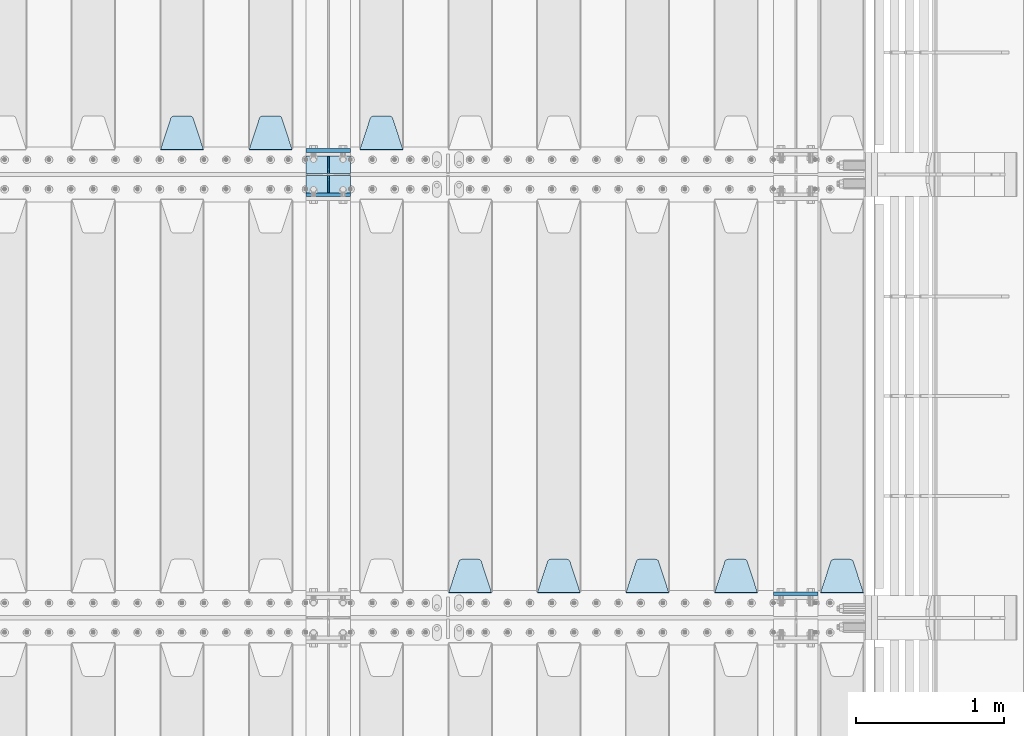
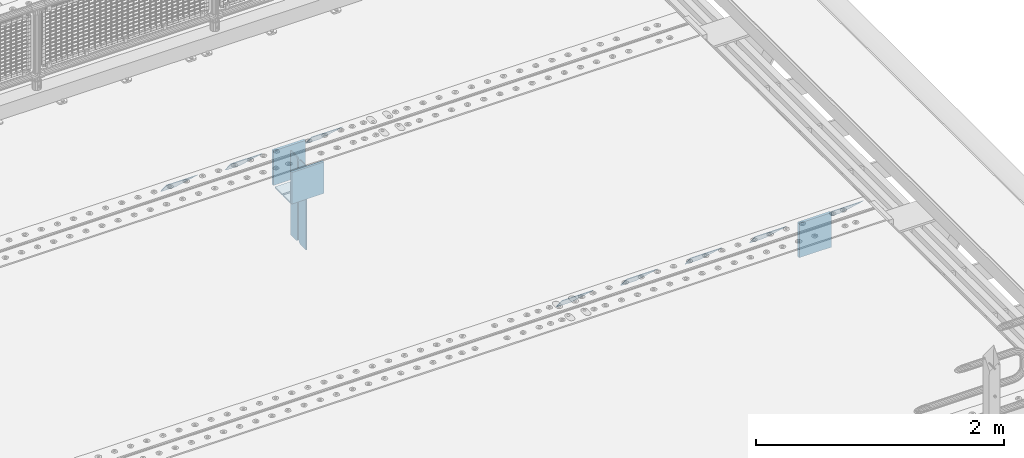
# One storey, part 189 of 219: 17 plates.
"""IFC2X3 building model written with IfcOpenShell, lengths in millimetres."""

from ifc_helpers import new_model, si_unit, frame, origin_with_axes, place, context, subcontext, project, spatial, faceted_brep, material, type_object, element, save


model = new_model("IFC2X3")

# Units and contexts
model_context = context("Model", 3, precision=1e-05, world=origin_with_axes())
body_context = subcontext(model_context, "Body", "Model", "MODEL_VIEW")
ifc_project = project(units=[si_unit("LENGTHUNIT", "METRE", prefix="MILLI"), si_unit("AREAUNIT", "SQUARE_METRE"), si_unit("VOLUMEUNIT", "CUBIC_METRE"), si_unit("MASSUNIT", "GRAM", prefix="KILO"), si_unit("TIMEUNIT", "SECOND"), si_unit("PLANEANGLEUNIT", "RADIAN"), si_unit("SOLIDANGLEUNIT", "STERADIAN"), si_unit("THERMODYNAMICTEMPERATUREUNIT", "DEGREE_CELSIUS"), si_unit("LUMINOUSINTENSITYUNIT", "LUMEN")], contexts=[model_context])

# Site, building, storey
site_placement = place(None, origin_with_axes())
site = spatial("IfcSite", under=ifc_project, at=site_placement, CompositionType="ELEMENT")
building_placement = place(site_placement, origin_with_axes())
building = spatial("IfcBuilding", under=site, at=building_placement, Name="Standard", CompositionType="ELEMENT")
storey_placement = place(building_placement, origin_with_axes())
storey = spatial("IfcBuildingStorey", under=building, at=storey_placement, Name="Undefined", CompositionType="ELEMENT", Elevation=0.0)

# Plates
ifc_material = material(Name="STEEL/S355N")
plate_type_1 = type_object("IfcPlateType", PredefinedType="NOTDEFINED")
for number, where, z_axis, x_axis in (
    (1, (13405.0, 27162.5, -340.000000000044), (0.0, 0.0, 1.0), (1.0, 0.0, 0.0)),
    (2, (10240.0, 30162.5, -340.000000000044), (0.0, 0.0, 1.0), (1.0, 0.0, 0.0)),
):
    element("IfcPlate", number, at=place(storey_placement, frame(where, z_axis=z_axis, x_axis=x_axis)), inside=storey, type_object=plate_type_1, material=ifc_material, context=body_context, shape_type="Brep", body=[
        faceted_brep([(0.0, -12.5, 0.0), (9.27684595808387e-10, -12.5, 340.0), (9.27684595808387e-10, 12.5, 340.0), (0.0, 12.5, 0.0), (300.0, -12.5, 340.0), (300.0, 12.5, 340.0), (300.0, -12.5, 0.0), (300.0, 12.5, 0.0)], [[[0, 1, 2, 3]], [[1, 4, 5, 2]], [[4, 6, 7, 5]], [[6, 0, 3, 7]], [[5, 7, 3, 2]], [[6, 4, 1, 0]]]),
    ])
plate_1_placement = place(storey_placement, frame((10240.0, 29862.5, -340.0), z_axis=(0.0, 0.0, 1.0), x_axis=(1.0, 0.0, 0.0)))
element("IfcPlate", 3, at=plate_1_placement, inside=storey, type_object=plate_type_1, material=ifc_material, context=body_context, shape_type="Brep", body=[
    faceted_brep([(0.0, -12.5, 0.0), (0.0, -12.5, 310.0), (0.0, 12.5, 310.0), (0.0, 12.5, 0.0), (300.0, -12.5, 310.0), (300.0, 12.5, 310.0), (300.0, -12.5, 0.0), (300.0, 12.5, 0.0)], [[[0, 1, 2, 3]], [[1, 4, 5, 2]], [[4, 6, 7, 5]], [[6, 0, 3, 7]], [[5, 7, 3, 2]], [[6, 4, 1, 0]]]),
])
plate_type_2 = type_object("IfcPlateType", PredefinedType="NOTDEFINED")
for number, where, z_axis, x_axis in (
    (4, (10240.0, 29992.0, -343.0), (0.0, -1.0, 0.0), (1.0, 0.0, 0.0)),
    (5, (10240.0, 30008.0, -343.0), (0.0, 1.0, 0.0), (1.0, 0.0, 0.0)),
):
    element("IfcPlate", number, at=place(storey_placement, frame(where, z_axis=z_axis, x_axis=x_axis)), inside=storey, type_object=plate_type_2, material=ifc_material, context=body_context, shape_type="Brep", body=[
        faceted_brep([(0.0, -7.0, 0.0), (0.0, -7.0, 117.0), (0.0, 7.0, 117.0), (0.0, 7.0, 0.0), (300.0, -7.0, 117.0), (300.0, 7.0, 117.0), (300.0, -7.0, 0.0), (300.0, 7.0, 0.0)], [[[0, 1, 2, 3]], [[1, 4, 5, 2]], [[4, 6, 7, 5]], [[6, 0, 3, 7]], [[5, 7, 3, 2]], [[6, 4, 1, 0]]]),
    ])
plate_type_3 = type_object("IfcPlateType", PredefinedType="NOTDEFINED")
for number, where, z_axis, x_axis in (
    (6, (10390.0, 30008.0, -30.0), (0.0, 0.0, -1.0), (0.0, 1.0, 0.0)),
    (7, (10390.0, 29992.0, -30.0), (0.0, 0.0, -1.0), (0.0, -1.0, 0.0)),
):
    element("IfcPlate", number, at=place(storey_placement, frame(where, z_axis=z_axis, x_axis=x_axis)), inside=storey, type_object=plate_type_3, material=ifc_material, context=body_context, shape_type="Brep", body=[
        faceted_brep([(0.0, -5.0, 30.0), (0.0, -5.0, 306.0), (0.0, 5.0, 306.0), (0.0, 5.0, 30.0), (117.0, -5.0, 306.0), (117.0, 5.0, 306.0), (117.0, -5.0, 0.0), (117.0, 5.0, 0.0), (30.0, -5.0, 0.0), (30.0, 5.0, 0.0), (24.7905546699913, -5.0, 0.455767409633758), (24.7905546699913, 5.0, 0.455767409633758), (19.7393957002278, -5.0, 1.80922137642275), (19.7393957002278, 5.0, 1.80922137642275), (15.0, -5.0, 4.01923788646684), (15.0, 5.0, 4.01923788646684), (10.7163717094008, -5.0, 7.01866670643066), (10.7163717094008, 5.0, 7.01866670643066), (7.01866670643358, -5.0, 10.7163717094038), (7.01866670643358, 5.0, 10.7163717094038), (4.01923788646673, -5.0, 15.0), (4.01923788646673, 5.0, 15.0), (1.80922137642483, -5.0, 19.7393957002299), (1.80922137642483, 5.0, 19.7393957002299), (0.455767409635882, -5.0, 24.7905546699921), (0.455767409635882, 5.0, 24.7905546699921)], [[[0, 1, 2, 3]], [[1, 4, 5, 2]], [[4, 6, 7, 5]], [[6, 8, 9, 7]], [[8, 10, 11, 9]], [[10, 12, 13, 11]], [[12, 14, 15, 13]], [[14, 16, 17, 15]], [[16, 18, 19, 17]], [[18, 20, 21, 19]], [[20, 22, 23, 21]], [[22, 24, 25, 23]], [[24, 0, 3, 25]], [[5, 7, 9, 11, 13, 15, 17, 19, 21, 23, 25, 3, 2]], [[24, 22, 20, 18, 16, 14, 12, 10, 8, 6, 4, 1, 0]]]),
    ])
for number, where, z_axis, x_axis in (
    (8, (10390.0, 29992.0, -350.0), (0.0, 0.0, -1.0), (0.0, -1.0, 0.0)),
    (9, (10390.0, 30008.0, -350.0), (0.0, 0.0, -1.0), (0.0, 1.0, 0.0)),
):
    element("IfcPlate", number, at=place(storey_placement, frame(where, z_axis=z_axis, x_axis=x_axis)), inside=storey, type_object=plate_type_3, material=ifc_material, context=body_context, shape_type="Brep", body=[
        faceted_brep([(0.0, -5.0, 0.0), (0.0, -5.0, 480.0), (0.0, 5.0, 480.0), (0.0, 5.0, 0.0), (0.455767409635882, -5.0, 485.209445330008), (0.455767409635882, 5.0, 485.209445330008), (1.80922137642483, -5.0, 490.26060429977), (1.80922137642483, 5.0, 490.26060429977), (4.01923788646673, -5.0, 495.0), (4.01923788646673, 5.0, 495.0), (7.01866670643358, -5.0, 499.283628290596), (7.01866670643358, 5.0, 499.283628290596), (10.7163717094008, -5.0, 502.981333293569), (10.7163717094008, 5.0, 502.981333293569), (15.0, -5.0, 505.980762113533), (15.0, 5.0, 505.980762113533), (19.7393957002278, -5.0, 508.190778623577), (19.7393957002278, 5.0, 508.190778623577), (24.7905546699913, -5.0, 509.544232590366), (24.7905546699913, 5.0, 509.544232590366), (30.0, -5.0, 510.0), (30.0, 5.0, 510.0), (117.0, -5.0, 510.0), (117.0, 5.0, 510.0), (117.0, -5.0, 0.0), (117.0, 5.0, 0.0)], [[[0, 1, 2, 3]], [[1, 4, 5, 2]], [[4, 6, 7, 5]], [[6, 8, 9, 7]], [[8, 10, 11, 9]], [[10, 12, 13, 11]], [[12, 14, 15, 13]], [[14, 16, 17, 15]], [[16, 18, 19, 17]], [[18, 20, 21, 19]], [[20, 22, 23, 21]], [[22, 24, 25, 23]], [[24, 0, 3, 25]], [[5, 7, 9, 11, 13, 15, 17, 19, 21, 23, 25, 3, 2]], [[24, 22, 20, 18, 16, 14, 12, 10, 8, 6, 4, 1, 0]]]),
    ])
plate_type_4 = type_object("IfcPlateType", PredefinedType="NOTDEFINED")
plate_2_placement = place(storey_placement, frame((14012.0, 27168.232233047, -1.76776695296758), z_axis=(0.0, 0.707106781186547, -0.707106781186548), x_axis=(-1.0, 0.0, 0.0)))
element("IfcPlate", 10, at=plate_2_placement, inside=storey, type_object=plate_type_4, material=ifc_material, context=body_context, shape_type="Brep", body=[
    faceted_brep([(0.0, -2.5, 0.0), (69.345504679477, -2.5, 300.171731424834), (69.345504679477, 2.49999999999636, 300.171731424831), (0.0, 2.5, 0.0), (70.9274061199576, -2.50000000000364, 304.8974424154), (70.9274061199576, 2.49999999999636, 304.8974424154), (73.3818627772307, -2.50000000000364, 309.234538108532), (73.3818627772307, 2.49999999999636, 309.234538108532), (76.6187032999569, -2.50000000000364, 313.023683126106), (76.6187032999569, 2.49999999999636, 313.023683126106), (80.5190132704993, -2.50000000000364, 316.125672595372), (80.5190132704993, 2.49999999999636, 316.125672595372), (84.9395038596831, -2.50000000000364, 318.426546230476), (84.9395038596831, 2.5, 318.426546230479), (89.7177759439237, -2.50000000000364, 319.841774983277), (89.7177759439237, 2.5, 319.841774983281), (94.6782862926502, -2.50000000000364, 320.319366455078), (94.6782862926502, 2.49999999999636, 320.319366455078), (195.32171370735, -2.50000000000364, 320.319366455078), (195.32171370735, 2.49999999999636, 320.319366455078), (200.282224056076, -2.50000000000364, 319.841774983277), (200.282224056076, 2.5, 319.841774983281), (205.060496140317, -2.50000000000364, 318.426546230476), (205.060496140317, 2.49999999999636, 318.426546230476), (209.480986729501, -2.50000000000364, 316.125672595372), (209.480986729501, 2.49999999999636, 316.125672595372), (213.381296700043, -2.50000000000364, 313.023683126106), (213.381296700043, 2.49999999999272, 313.023683126106), (216.618137222769, -2.50000000000364, 309.234538108529), (216.618137222769, 2.49999999999636, 309.234538108525), (219.072593880042, -2.50000000000364, 304.8974424154), (219.072593880042, 2.49999999999636, 304.8974424154), (220.654495320523, -2.5, 300.171731424834), (220.654495320523, 2.49999999999636, 300.171731424831), (290.0, -2.50000000000364, 3.63797880709171e-12), (290.0, 2.49999999999636, 0.0)], [[[0, 1, 2, 3]], [[1, 4, 5, 2]], [[4, 6, 7, 5]], [[6, 8, 9, 7]], [[8, 10, 11, 9]], [[10, 12, 13, 11]], [[12, 14, 15, 13]], [[14, 16, 17, 15]], [[16, 18, 19, 17]], [[18, 20, 21, 19]], [[20, 22, 23, 21]], [[22, 24, 25, 23]], [[24, 26, 27, 25]], [[26, 28, 29, 27]], [[28, 30, 31, 29]], [[30, 32, 33, 31]], [[32, 34, 35, 33]], [[34, 0, 3, 35]], [[5, 7, 9, 11, 13, 15, 17, 19, 21, 23, 25, 27, 29, 31, 33, 35, 3, 2]], [[34, 32, 30, 28, 26, 24, 22, 20, 18, 16, 14, 12, 10, 8, 6, 4, 1, 0]]]),
])
plate_3_placement = place(storey_placement, frame((13295.0, 27168.232233047, -1.76776695296758), z_axis=(0.0, 0.707106781186547, -0.707106781186548), x_axis=(-1.0, 0.0, 0.0)))
element("IfcPlate", 11, at=plate_3_placement, inside=storey, type_object=plate_type_4, material=ifc_material, context=body_context, shape_type="Brep", body=[
    faceted_brep([(0.0, -2.5, 0.0), (69.345504679477, -2.5, 300.171731424834), (69.345504679477, 2.49999999999636, 300.171731424831), (0.0, 2.5, 0.0), (70.9274061199576, -2.50000000000364, 304.8974424154), (70.9274061199576, 2.49999999999636, 304.8974424154), (73.3818627772307, -2.50000000000364, 309.234538108532), (73.3818627772307, 2.49999999999636, 309.234538108532), (76.6187032999569, -2.50000000000364, 313.023683126106), (76.6187032999569, 2.49999999999636, 313.023683126106), (80.5190132704993, -2.50000000000364, 316.125672595372), (80.5190132704993, 2.49999999999636, 316.125672595372), (84.9395038596831, -2.50000000000364, 318.426546230476), (84.9395038596831, 2.5, 318.426546230479), (89.7177759439237, -2.50000000000364, 319.841774983277), (89.7177759439237, 2.5, 319.841774983281), (94.6782862926502, -2.50000000000364, 320.319366455078), (94.6782862926502, 2.49999999999636, 320.319366455078), (195.32171370735, -2.50000000000364, 320.319366455078), (195.32171370735, 2.49999999999636, 320.319366455078), (200.282224056076, -2.50000000000364, 319.841774983277), (200.282224056076, 2.5, 319.841774983281), (205.060496140317, -2.50000000000364, 318.426546230476), (205.060496140317, 2.49999999999636, 318.426546230476), (209.480986729501, -2.50000000000364, 316.125672595372), (209.480986729501, 2.49999999999636, 316.125672595372), (213.381296700043, -2.50000000000364, 313.023683126106), (213.381296700043, 2.49999999999272, 313.023683126106), (216.618137222769, -2.50000000000364, 309.234538108529), (216.618137222769, 2.49999999999636, 309.234538108525), (219.072593880042, -2.50000000000364, 304.8974424154), (219.072593880042, 2.49999999999636, 304.8974424154), (220.654495320523, -2.5, 300.171731424834), (220.654495320523, 2.49999999999636, 300.171731424831), (290.0, -2.50000000000364, 3.63797880709171e-12), (290.0, 2.49999999999636, 0.0)], [[[0, 1, 2, 3]], [[1, 4, 5, 2]], [[4, 6, 7, 5]], [[6, 8, 9, 7]], [[8, 10, 11, 9]], [[10, 12, 13, 11]], [[12, 14, 15, 13]], [[14, 16, 17, 15]], [[16, 18, 19, 17]], [[18, 20, 21, 19]], [[20, 22, 23, 21]], [[22, 24, 25, 23]], [[24, 26, 27, 25]], [[26, 28, 29, 27]], [[28, 30, 31, 29]], [[30, 32, 33, 31]], [[32, 34, 35, 33]], [[34, 0, 3, 35]], [[5, 7, 9, 11, 13, 15, 17, 19, 21, 23, 25, 27, 29, 31, 33, 35, 3, 2]], [[34, 32, 30, 28, 26, 24, 22, 20, 18, 16, 14, 12, 10, 8, 6, 4, 1, 0]]]),
])
plate_4_placement = place(storey_placement, frame((12695.0, 27168.232233047, -1.76776695296758), z_axis=(0.0, 0.707106781186547, -0.707106781186548), x_axis=(-1.0, 0.0, 0.0)))
element("IfcPlate", 12, at=plate_4_placement, inside=storey, type_object=plate_type_4, material=ifc_material, context=body_context, shape_type="Brep", body=[
    faceted_brep([(0.0, -2.5, 0.0), (69.345504679477, -2.5, 300.171731424834), (69.345504679477, 2.49999999999636, 300.171731424831), (0.0, 2.5, 0.0), (70.9274061199576, -2.50000000000364, 304.8974424154), (70.9274061199576, 2.49999999999636, 304.8974424154), (73.3818627772307, -2.50000000000364, 309.234538108532), (73.3818627772307, 2.49999999999636, 309.234538108532), (76.6187032999569, -2.50000000000364, 313.023683126106), (76.6187032999569, 2.49999999999636, 313.023683126106), (80.5190132704993, -2.50000000000364, 316.125672595372), (80.5190132704993, 2.49999999999636, 316.125672595372), (84.9395038596831, -2.50000000000364, 318.426546230476), (84.9395038596831, 2.5, 318.426546230479), (89.7177759439237, -2.50000000000364, 319.841774983277), (89.7177759439237, 2.5, 319.841774983281), (94.6782862926502, -2.50000000000364, 320.319366455078), (94.6782862926502, 2.49999999999636, 320.319366455078), (195.32171370735, -2.50000000000364, 320.319366455078), (195.32171370735, 2.49999999999636, 320.319366455078), (200.282224056076, -2.50000000000364, 319.841774983277), (200.282224056076, 2.5, 319.841774983281), (205.060496140317, -2.50000000000364, 318.426546230476), (205.060496140317, 2.49999999999636, 318.426546230476), (209.480986729501, -2.50000000000364, 316.125672595372), (209.480986729501, 2.49999999999636, 316.125672595372), (213.381296700043, -2.50000000000364, 313.023683126106), (213.381296700043, 2.49999999999272, 313.023683126106), (216.618137222769, -2.50000000000364, 309.234538108529), (216.618137222769, 2.49999999999636, 309.234538108525), (219.072593880042, -2.50000000000364, 304.8974424154), (219.072593880042, 2.49999999999636, 304.8974424154), (220.654495320523, -2.5, 300.171731424834), (220.654495320523, 2.49999999999636, 300.171731424831), (290.0, -2.50000000000364, 3.63797880709171e-12), (290.0, 2.49999999999636, 0.0)], [[[0, 1, 2, 3]], [[1, 4, 5, 2]], [[4, 6, 7, 5]], [[6, 8, 9, 7]], [[8, 10, 11, 9]], [[10, 12, 13, 11]], [[12, 14, 15, 13]], [[14, 16, 17, 15]], [[16, 18, 19, 17]], [[18, 20, 21, 19]], [[20, 22, 23, 21]], [[22, 24, 25, 23]], [[24, 26, 27, 25]], [[26, 28, 29, 27]], [[28, 30, 31, 29]], [[30, 32, 33, 31]], [[32, 34, 35, 33]], [[34, 0, 3, 35]], [[5, 7, 9, 11, 13, 15, 17, 19, 21, 23, 25, 27, 29, 31, 33, 35, 3, 2]], [[34, 32, 30, 28, 26, 24, 22, 20, 18, 16, 14, 12, 10, 8, 6, 4, 1, 0]]]),
])
plate_5_placement = place(storey_placement, frame((12095.0, 27168.232233047, -1.76776695296758), z_axis=(0.0, 0.707106781186547, -0.707106781186548), x_axis=(-1.0, 0.0, 0.0)))
element("IfcPlate", 13, at=plate_5_placement, inside=storey, type_object=plate_type_4, material=ifc_material, context=body_context, shape_type="Brep", body=[
    faceted_brep([(0.0, -2.5, 0.0), (69.345504679477, -2.5, 300.171731424834), (69.345504679477, 2.49999999999636, 300.171731424831), (0.0, 2.5, 0.0), (70.9274061199576, -2.50000000000364, 304.8974424154), (70.9274061199576, 2.49999999999636, 304.8974424154), (73.3818627772307, -2.50000000000364, 309.234538108532), (73.3818627772307, 2.49999999999636, 309.234538108532), (76.6187032999569, -2.50000000000364, 313.023683126106), (76.6187032999569, 2.49999999999636, 313.023683126106), (80.5190132704993, -2.50000000000364, 316.125672595372), (80.5190132704993, 2.49999999999636, 316.125672595372), (84.9395038596831, -2.50000000000364, 318.426546230476), (84.9395038596831, 2.5, 318.426546230479), (89.7177759439237, -2.50000000000364, 319.841774983277), (89.7177759439237, 2.5, 319.841774983281), (94.6782862926502, -2.50000000000364, 320.319366455078), (94.6782862926502, 2.49999999999636, 320.319366455078), (195.32171370735, -2.50000000000364, 320.319366455078), (195.32171370735, 2.49999999999636, 320.319366455078), (200.282224056076, -2.50000000000364, 319.841774983277), (200.282224056076, 2.5, 319.841774983281), (205.060496140317, -2.50000000000364, 318.426546230476), (205.060496140317, 2.49999999999636, 318.426546230476), (209.480986729501, -2.50000000000364, 316.125672595372), (209.480986729501, 2.49999999999636, 316.125672595372), (213.381296700043, -2.50000000000364, 313.023683126106), (213.381296700043, 2.49999999999272, 313.023683126106), (216.618137222769, -2.50000000000364, 309.234538108529), (216.618137222769, 2.49999999999636, 309.234538108525), (219.072593880042, -2.50000000000364, 304.8974424154), (219.072593880042, 2.49999999999636, 304.8974424154), (220.654495320523, -2.5, 300.171731424834), (220.654495320523, 2.49999999999636, 300.171731424831), (290.0, -2.50000000000364, 3.63797880709171e-12), (290.0, 2.49999999999636, 0.0)], [[[0, 1, 2, 3]], [[1, 4, 5, 2]], [[4, 6, 7, 5]], [[6, 8, 9, 7]], [[8, 10, 11, 9]], [[10, 12, 13, 11]], [[12, 14, 15, 13]], [[14, 16, 17, 15]], [[16, 18, 19, 17]], [[18, 20, 21, 19]], [[20, 22, 23, 21]], [[22, 24, 25, 23]], [[24, 26, 27, 25]], [[26, 28, 29, 27]], [[28, 30, 31, 29]], [[30, 32, 33, 31]], [[32, 34, 35, 33]], [[34, 0, 3, 35]], [[5, 7, 9, 11, 13, 15, 17, 19, 21, 23, 25, 27, 29, 31, 33, 35, 3, 2]], [[34, 32, 30, 28, 26, 24, 22, 20, 18, 16, 14, 12, 10, 8, 6, 4, 1, 0]]]),
])
plate_6_placement = place(storey_placement, frame((11495.0, 27168.232233047, -1.76776695296758), z_axis=(0.0, 0.707106781186547, -0.707106781186548), x_axis=(-1.0, 0.0, 0.0)))
element("IfcPlate", 14, at=plate_6_placement, inside=storey, type_object=plate_type_4, material=ifc_material, context=body_context, shape_type="Brep", body=[
    faceted_brep([(0.0, -2.5, 0.0), (69.345504679477, -2.5, 300.171731424834), (69.345504679477, 2.49999999999636, 300.171731424831), (0.0, 2.5, 0.0), (70.9274061199576, -2.50000000000364, 304.8974424154), (70.9274061199576, 2.49999999999636, 304.8974424154), (73.3818627772307, -2.50000000000364, 309.234538108532), (73.3818627772307, 2.49999999999636, 309.234538108532), (76.6187032999569, -2.50000000000364, 313.023683126106), (76.6187032999569, 2.49999999999636, 313.023683126106), (80.5190132704993, -2.50000000000364, 316.125672595372), (80.5190132704993, 2.49999999999636, 316.125672595372), (84.9395038596831, -2.50000000000364, 318.426546230476), (84.9395038596831, 2.5, 318.426546230479), (89.7177759439237, -2.50000000000364, 319.841774983277), (89.7177759439237, 2.5, 319.841774983281), (94.6782862926502, -2.50000000000364, 320.319366455078), (94.6782862926502, 2.49999999999636, 320.319366455078), (195.32171370735, -2.50000000000364, 320.319366455078), (195.32171370735, 2.49999999999636, 320.319366455078), (200.282224056076, -2.50000000000364, 319.841774983277), (200.282224056076, 2.5, 319.841774983281), (205.060496140317, -2.50000000000364, 318.426546230476), (205.060496140317, 2.49999999999636, 318.426546230476), (209.480986729501, -2.50000000000364, 316.125672595372), (209.480986729501, 2.49999999999636, 316.125672595372), (213.381296700043, -2.50000000000364, 313.023683126106), (213.381296700043, 2.49999999999272, 313.023683126106), (216.618137222769, -2.50000000000364, 309.234538108529), (216.618137222769, 2.49999999999636, 309.234538108525), (219.072593880042, -2.50000000000364, 304.8974424154), (219.072593880042, 2.49999999999636, 304.8974424154), (220.654495320523, -2.5, 300.171731424834), (220.654495320523, 2.49999999999636, 300.171731424831), (290.0, -2.50000000000364, 3.63797880709171e-12), (290.0, 2.49999999999636, 0.0)], [[[0, 1, 2, 3]], [[1, 4, 5, 2]], [[4, 6, 7, 5]], [[6, 8, 9, 7]], [[8, 10, 11, 9]], [[10, 12, 13, 11]], [[12, 14, 15, 13]], [[14, 16, 17, 15]], [[16, 18, 19, 17]], [[18, 20, 21, 19]], [[20, 22, 23, 21]], [[22, 24, 25, 23]], [[24, 26, 27, 25]], [[26, 28, 29, 27]], [[28, 30, 31, 29]], [[30, 32, 33, 31]], [[32, 34, 35, 33]], [[34, 0, 3, 35]], [[5, 7, 9, 11, 13, 15, 17, 19, 21, 23, 25, 27, 29, 31, 33, 35, 3, 2]], [[34, 32, 30, 28, 26, 24, 22, 20, 18, 16, 14, 12, 10, 8, 6, 4, 1, 0]]]),
])
plate_7_placement = place(storey_placement, frame((10895.0, 30168.232233047, -1.76776695296758), z_axis=(0.0, 0.707106781186547, -0.707106781186548), x_axis=(-1.0, 0.0, 0.0)))
element("IfcPlate", 15, at=plate_7_placement, inside=storey, type_object=plate_type_4, material=ifc_material, context=body_context, shape_type="Brep", body=[
    faceted_brep([(0.0, -2.5, 0.0), (69.345504679477, -2.5, 300.171731424834), (69.345504679477, 2.49999999999636, 300.171731424831), (0.0, 2.5, 0.0), (70.9274061199576, -2.50000000000364, 304.8974424154), (70.9274061199576, 2.49999999999636, 304.8974424154), (73.3818627772307, -2.50000000000364, 309.234538108532), (73.3818627772307, 2.49999999999636, 309.234538108532), (76.6187032999569, -2.50000000000364, 313.023683126106), (76.6187032999569, 2.49999999999636, 313.023683126106), (80.5190132704993, -2.50000000000364, 316.125672595372), (80.5190132704993, 2.49999999999636, 316.125672595372), (84.9395038596831, -2.50000000000364, 318.426546230476), (84.9395038596831, 2.5, 318.426546230479), (89.7177759439237, -2.50000000000364, 319.841774983277), (89.7177759439237, 2.5, 319.841774983281), (94.6782862926502, -2.50000000000364, 320.319366455078), (94.6782862926502, 2.49999999999636, 320.319366455078), (195.32171370735, -2.50000000000364, 320.319366455078), (195.32171370735, 2.49999999999636, 320.319366455078), (200.282224056076, -2.50000000000364, 319.841774983277), (200.282224056076, 2.5, 319.841774983281), (205.060496140317, -2.50000000000364, 318.426546230476), (205.060496140317, 2.49999999999636, 318.426546230476), (209.480986729501, -2.50000000000364, 316.125672595372), (209.480986729501, 2.49999999999636, 316.125672595372), (213.381296700043, -2.50000000000364, 313.023683126106), (213.381296700043, 2.49999999999272, 313.023683126106), (216.618137222769, -2.50000000000364, 309.234538108529), (216.618137222769, 2.49999999999636, 309.234538108525), (219.072593880042, -2.50000000000364, 304.8974424154), (219.072593880042, 2.49999999999636, 304.8974424154), (220.654495320523, -2.5, 300.171731424834), (220.654495320523, 2.49999999999636, 300.171731424831), (290.0, -2.50000000000364, 3.63797880709171e-12), (290.0, 2.49999999999636, 0.0)], [[[0, 1, 2, 3]], [[1, 4, 5, 2]], [[4, 6, 7, 5]], [[6, 8, 9, 7]], [[8, 10, 11, 9]], [[10, 12, 13, 11]], [[12, 14, 15, 13]], [[14, 16, 17, 15]], [[16, 18, 19, 17]], [[18, 20, 21, 19]], [[20, 22, 23, 21]], [[22, 24, 25, 23]], [[24, 26, 27, 25]], [[26, 28, 29, 27]], [[28, 30, 31, 29]], [[30, 32, 33, 31]], [[32, 34, 35, 33]], [[34, 0, 3, 35]], [[5, 7, 9, 11, 13, 15, 17, 19, 21, 23, 25, 27, 29, 31, 33, 35, 3, 2]], [[34, 32, 30, 28, 26, 24, 22, 20, 18, 16, 14, 12, 10, 8, 6, 4, 1, 0]]]),
])
plate_8_placement = place(storey_placement, frame((10145.0, 30168.232233047, -1.76776695296758), z_axis=(0.0, 0.707106781186547, -0.707106781186548), x_axis=(-1.0, 0.0, 0.0)))
element("IfcPlate", 16, at=plate_8_placement, inside=storey, type_object=plate_type_4, material=ifc_material, context=body_context, shape_type="Brep", body=[
    faceted_brep([(0.0, -2.5, 0.0), (69.345504679477, -2.5, 300.171731424834), (69.345504679477, 2.49999999999636, 300.171731424831), (0.0, 2.5, 0.0), (70.9274061199576, -2.50000000000364, 304.8974424154), (70.9274061199576, 2.49999999999636, 304.8974424154), (73.3818627772307, -2.50000000000364, 309.234538108532), (73.3818627772307, 2.49999999999636, 309.234538108532), (76.6187032999569, -2.50000000000364, 313.023683126106), (76.6187032999569, 2.49999999999636, 313.023683126106), (80.5190132704993, -2.50000000000364, 316.125672595372), (80.5190132704993, 2.49999999999636, 316.125672595372), (84.9395038596831, -2.50000000000364, 318.426546230476), (84.9395038596831, 2.5, 318.426546230479), (89.7177759439237, -2.50000000000364, 319.841774983277), (89.7177759439237, 2.5, 319.841774983281), (94.6782862926502, -2.50000000000364, 320.319366455078), (94.6782862926502, 2.49999999999636, 320.319366455078), (195.32171370735, -2.50000000000364, 320.319366455078), (195.32171370735, 2.49999999999636, 320.319366455078), (200.282224056076, -2.50000000000364, 319.841774983277), (200.282224056076, 2.5, 319.841774983281), (205.060496140317, -2.50000000000364, 318.426546230476), (205.060496140317, 2.49999999999636, 318.426546230476), (209.480986729501, -2.50000000000364, 316.125672595372), (209.480986729501, 2.49999999999636, 316.125672595372), (213.381296700043, -2.50000000000364, 313.023683126106), (213.381296700043, 2.49999999999272, 313.023683126106), (216.618137222769, -2.50000000000364, 309.234538108529), (216.618137222769, 2.49999999999636, 309.234538108525), (219.072593880042, -2.50000000000364, 304.8974424154), (219.072593880042, 2.49999999999636, 304.8974424154), (220.654495320523, -2.5, 300.171731424834), (220.654495320523, 2.49999999999636, 300.171731424831), (290.0, -2.50000000000364, 3.63797880709171e-12), (290.0, 2.49999999999636, 0.0)], [[[0, 1, 2, 3]], [[1, 4, 5, 2]], [[4, 6, 7, 5]], [[6, 8, 9, 7]], [[8, 10, 11, 9]], [[10, 12, 13, 11]], [[12, 14, 15, 13]], [[14, 16, 17, 15]], [[16, 18, 19, 17]], [[18, 20, 21, 19]], [[20, 22, 23, 21]], [[22, 24, 25, 23]], [[24, 26, 27, 25]], [[26, 28, 29, 27]], [[28, 30, 31, 29]], [[30, 32, 33, 31]], [[32, 34, 35, 33]], [[34, 0, 3, 35]], [[5, 7, 9, 11, 13, 15, 17, 19, 21, 23, 25, 27, 29, 31, 33, 35, 3, 2]], [[34, 32, 30, 28, 26, 24, 22, 20, 18, 16, 14, 12, 10, 8, 6, 4, 1, 0]]]),
])
plate_9_placement = place(storey_placement, frame((9545.0, 30168.232233047, -1.76776695296758), z_axis=(0.0, 0.707106781186547, -0.707106781186548), x_axis=(-1.0, 0.0, 0.0)))
element("IfcPlate", 17, at=plate_9_placement, inside=storey, type_object=plate_type_4, material=ifc_material, context=body_context, shape_type="Brep", body=[
    faceted_brep([(0.0, -2.5, 0.0), (69.345504679477, -2.5, 300.171731424834), (69.345504679477, 2.49999999999636, 300.171731424831), (0.0, 2.5, 0.0), (70.9274061199576, -2.50000000000364, 304.8974424154), (70.9274061199576, 2.49999999999636, 304.8974424154), (73.3818627772307, -2.50000000000364, 309.234538108532), (73.3818627772307, 2.49999999999636, 309.234538108532), (76.6187032999569, -2.50000000000364, 313.023683126106), (76.6187032999569, 2.49999999999636, 313.023683126106), (80.5190132704993, -2.50000000000364, 316.125672595372), (80.5190132704993, 2.49999999999636, 316.125672595372), (84.9395038596831, -2.50000000000364, 318.426546230476), (84.9395038596831, 2.5, 318.426546230479), (89.7177759439237, -2.50000000000364, 319.841774983277), (89.7177759439237, 2.5, 319.841774983281), (94.6782862926502, -2.50000000000364, 320.319366455078), (94.6782862926502, 2.49999999999636, 320.319366455078), (195.32171370735, -2.50000000000364, 320.319366455078), (195.32171370735, 2.49999999999636, 320.319366455078), (200.282224056076, -2.50000000000364, 319.841774983277), (200.282224056076, 2.5, 319.841774983281), (205.060496140317, -2.50000000000364, 318.426546230476), (205.060496140317, 2.49999999999636, 318.426546230476), (209.480986729501, -2.50000000000364, 316.125672595372), (209.480986729501, 2.49999999999636, 316.125672595372), (213.381296700043, -2.50000000000364, 313.023683126106), (213.381296700043, 2.49999999999272, 313.023683126106), (216.618137222769, -2.50000000000364, 309.234538108529), (216.618137222769, 2.49999999999636, 309.234538108525), (219.072593880042, -2.50000000000364, 304.8974424154), (219.072593880042, 2.49999999999636, 304.8974424154), (220.654495320523, -2.5, 300.171731424834), (220.654495320523, 2.49999999999636, 300.171731424831), (290.0, -2.50000000000364, 3.63797880709171e-12), (290.0, 2.49999999999636, 0.0)], [[[0, 1, 2, 3]], [[1, 4, 5, 2]], [[4, 6, 7, 5]], [[6, 8, 9, 7]], [[8, 10, 11, 9]], [[10, 12, 13, 11]], [[12, 14, 15, 13]], [[14, 16, 17, 15]], [[16, 18, 19, 17]], [[18, 20, 21, 19]], [[20, 22, 23, 21]], [[22, 24, 25, 23]], [[24, 26, 27, 25]], [[26, 28, 29, 27]], [[28, 30, 31, 29]], [[30, 32, 33, 31]], [[32, 34, 35, 33]], [[34, 0, 3, 35]], [[5, 7, 9, 11, 13, 15, 17, 19, 21, 23, 25, 27, 29, 31, 33, 35, 3, 2]], [[34, 32, 30, 28, 26, 24, 22, 20, 18, 16, 14, 12, 10, 8, 6, 4, 1, 0]]]),
])

save(model, "model.ifc")
